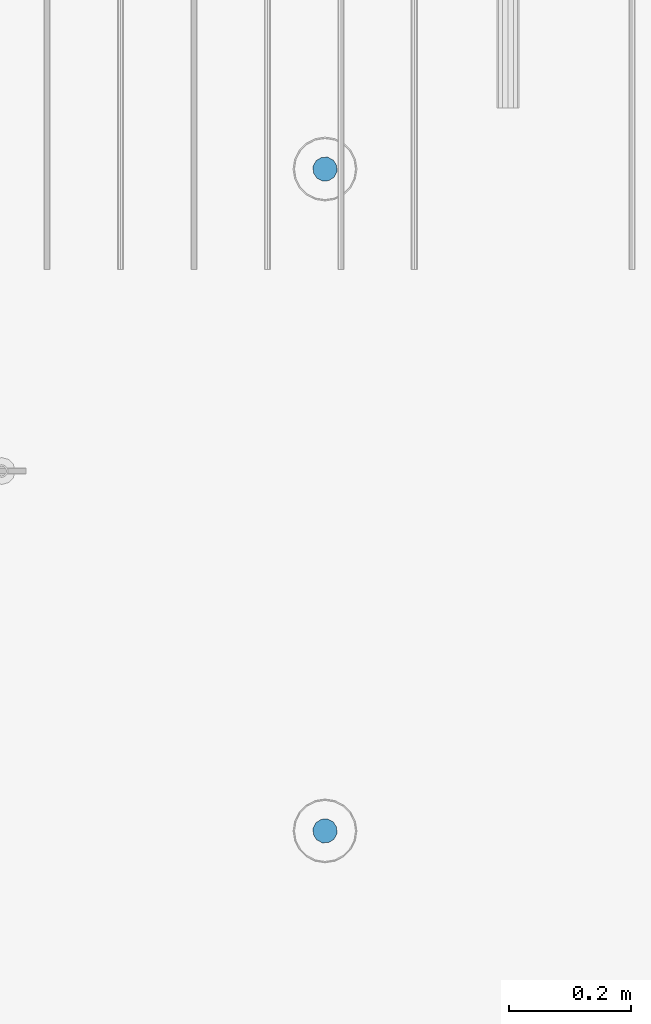
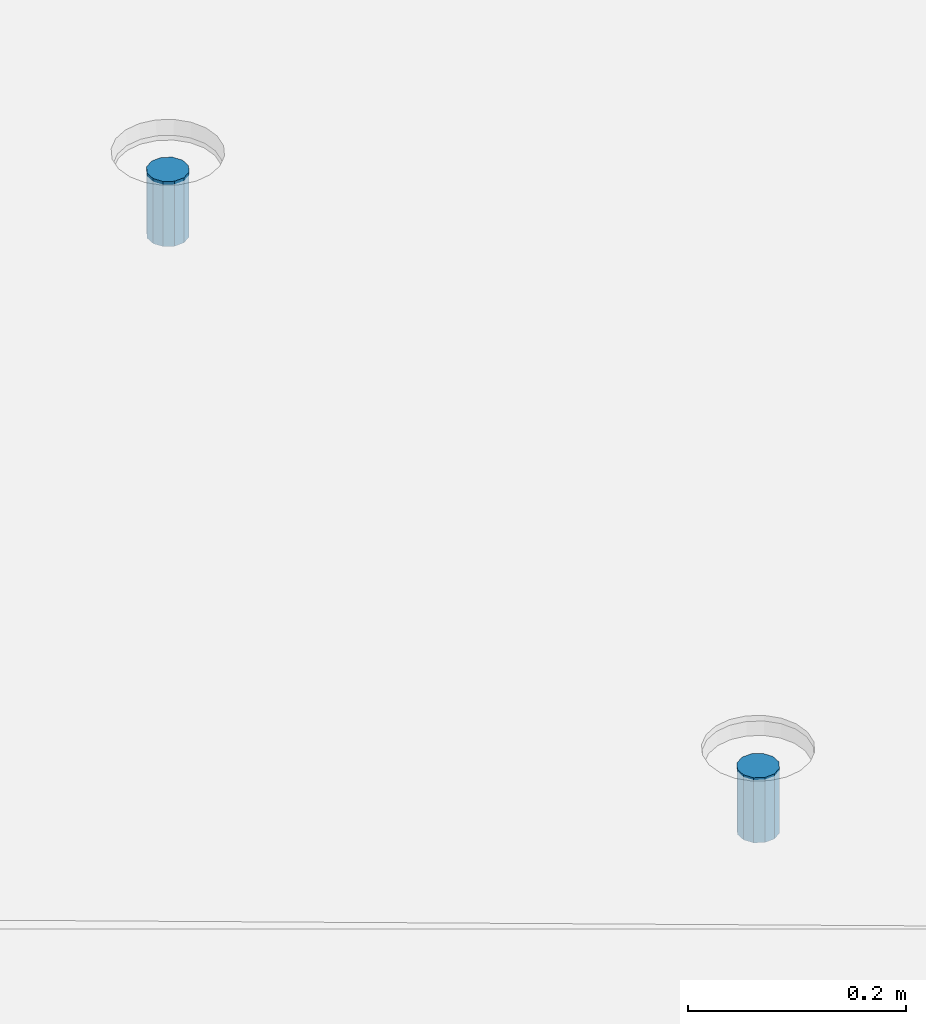
# One storey, part 16 of 153: 2 columns, 3 elements without a shape of their own.
"""IFC2X3 building model written with IfcOpenShell, lengths in millimetres."""

from ifc_helpers import new_model, si_unit, frame, origin_with_axes, place, context, subcontext, project, spatial, faceted_brep, material, type_object, element, aggregate, save


model = new_model("IFC2X3")

# Units and contexts
model_context = context("Model", 3, precision=1e-05, world=origin_with_axes())
body_context = subcontext(model_context, "Body", "Model", "MODEL_VIEW")
ifc_project = project(units=[si_unit("LENGTHUNIT", "METRE", prefix="MILLI"), si_unit("AREAUNIT", "SQUARE_METRE"), si_unit("VOLUMEUNIT", "CUBIC_METRE"), si_unit("MASSUNIT", "GRAM", prefix="KILO"), si_unit("TIMEUNIT", "SECOND"), si_unit("PLANEANGLEUNIT", "RADIAN"), si_unit("SOLIDANGLEUNIT", "STERADIAN"), si_unit("THERMODYNAMICTEMPERATUREUNIT", "DEGREE_CELSIUS"), si_unit("LUMINOUSINTENSITYUNIT", "LUMEN")], contexts=[model_context])

# Site, building, storey
site_placement = place(None, origin_with_axes())
site = spatial("IfcSite", under=ifc_project, at=site_placement, CompositionType="ELEMENT")
building_placement = place(site_placement, origin_with_axes())
building = spatial("IfcBuilding", under=site, at=building_placement, CompositionType="ELEMENT")
storey_placement = place(building_placement, origin_with_axes())
storey = spatial("IfcBuildingStorey", under=building, at=storey_placement, Name="8", CompositionType="ELEMENT", Elevation=0.0)

# Assemblies, columns
assembly_1_placement = place(storey_placement, origin_with_axes())
assembly_1 = element("IfcElementAssembly", 1, at=assembly_1_placement, inside=storey, AssemblyPlace="NOTDEFINED", PredefinedType="REINFORCEMENT_UNIT")
assembly_2_placement = place(assembly_1_placement, origin_with_axes())
assembly_2 = element("IfcElementAssembly", 2, at=assembly_2_placement, Name="Steel Assembly", AssemblyPlace="NOTDEFINED", PredefinedType="RIGID_FRAME")
ifc_material = material(Name="STEEL/Steel_Undefined")
column_type = type_object("IfcColumnType", Name="D40", PredefinedType="NOTDEFINED")
column_1_placement = place(assembly_2_placement, frame((32409.9950440812, 7079.98280261383, 102624.0), z_axis=(-0.74071949690495, 0.671814428913794, 2.84800000335798e-06), x_axis=(3.26300002209467e-06, -6.4100000499712e-07, 0.999999999994471)))
column_1 = element("IfcColumn", 3, at=column_1_placement, type_object=column_type, material=ifc_material, Name="R-Group R", ObjectType="D40", context=body_context, shape_type="Brep", body=[
    faceted_brep([(0.0, -20.0, 0.0), (0.0, -17.3205080756888, -10.0), (73.0, -17.3205080756852, -9.99999999999636), (73.0, -19.9999999999964, 3.63797880709171e-12), (0.0, -10.0, -17.3205080756888), (73.0, -10.0, -17.3205080756834), (0.0, 0.0, -20.0), (73.0, 3.63797880709171e-12, -19.9999999999964), (0.0, 10.0, -17.3205080756888), (73.0, 10.0000000000036, -17.3205080756834), (0.0, 17.3205080756888, -10.0), (73.0, 17.3205080756925, -9.99999999999818), (0.0, 20.0, 0.0), (73.0, 20.0, 3.63797880709171e-12), (0.0, 17.3205080756888, 10.0), (73.0, 17.3205080756888, 10.0000000000036), (0.0, 10.0, 17.3205080756888), (73.0, 10.0000000000036, 17.3205080756961), (0.0, 0.0, 20.0), (73.0, 3.63797880709171e-12, 20.0000000000036), (0.0, -10.0, 17.3205080756888), (73.0, -9.99999999999636, 17.3205080756925), (0.0, -17.3205080756888, 10.0), (73.0, -17.3205080756852, 10.0000000000055)], [[[0, 1, 2, 3]], [[1, 4, 5, 2]], [[4, 6, 7, 5]], [[6, 8, 9, 7]], [[8, 10, 11, 9]], [[10, 12, 13, 11]], [[12, 14, 15, 13]], [[14, 16, 17, 15]], [[16, 18, 19, 17]], [[18, 20, 21, 19]], [[20, 22, 23, 21]], [[22, 0, 3, 23]], [[5, 7, 9, 11, 13, 15, 17, 19, 21, 23, 3, 2]], [[22, 20, 18, 16, 14, 12, 10, 8, 6, 4, 1, 0]]]),
])
aggregate(assembly_2, [column_1])
assembly_3_placement = place(assembly_1_placement, origin_with_axes())
assembly_3 = element("IfcElementAssembly", 4, at=assembly_3_placement, Name="Steel Assembly", AssemblyPlace="NOTDEFINED", PredefinedType="RIGID_FRAME")
aggregate(assembly_1, [assembly_2, assembly_3])
column_2_placement = place(assembly_3_placement, frame((32409.9950440812, 5994.98280261383, 102613.0), z_axis=(-0.74071949690495, 0.671814428913794, 2.84800000335798e-06), x_axis=(3.26300002209467e-06, -6.4100000499712e-07, 0.999999999994471)))
column_2 = element("IfcColumn", 5, at=column_2_placement, type_object=column_type, material=ifc_material, Name="R-Group R", ObjectType="D40", context=body_context, shape_type="Brep", body=[
    faceted_brep([(0.0, -20.0, 0.0), (0.0, -17.3205080756888, -10.0), (73.0, -17.3205080756852, -9.99999999999636), (73.0, -19.9999999999964, 3.63797880709171e-12), (0.0, -10.0, -17.3205080756888), (73.0, -10.0, -17.3205080756834), (0.0, 0.0, -20.0), (73.0, 3.63797880709171e-12, -19.9999999999964), (0.0, 10.0, -17.3205080756888), (73.0, 10.0000000000036, -17.3205080756834), (0.0, 17.3205080756888, -10.0), (73.0, 17.3205080756925, -9.99999999999818), (0.0, 20.0, 0.0), (73.0, 20.0, 3.63797880709171e-12), (0.0, 17.3205080756888, 10.0), (73.0, 17.3205080756888, 10.0000000000036), (0.0, 10.0, 17.3205080756888), (73.0, 10.0000000000036, 17.3205080756961), (0.0, 0.0, 20.0), (73.0, 3.63797880709171e-12, 20.0000000000036), (0.0, -10.0, 17.3205080756888), (73.0, -9.99999999999636, 17.3205080756925), (0.0, -17.3205080756888, 10.0), (73.0, -17.3205080756852, 10.0000000000055)], [[[0, 1, 2, 3]], [[1, 4, 5, 2]], [[4, 6, 7, 5]], [[6, 8, 9, 7]], [[8, 10, 11, 9]], [[10, 12, 13, 11]], [[12, 14, 15, 13]], [[14, 16, 17, 15]], [[16, 18, 19, 17]], [[18, 20, 21, 19]], [[20, 22, 23, 21]], [[22, 0, 3, 23]], [[5, 7, 9, 11, 13, 15, 17, 19, 21, 23, 3, 2]], [[22, 20, 18, 16, 14, 12, 10, 8, 6, 4, 1, 0]]]),
])
aggregate(assembly_3, [column_2])

save(model, "model.ifc")
